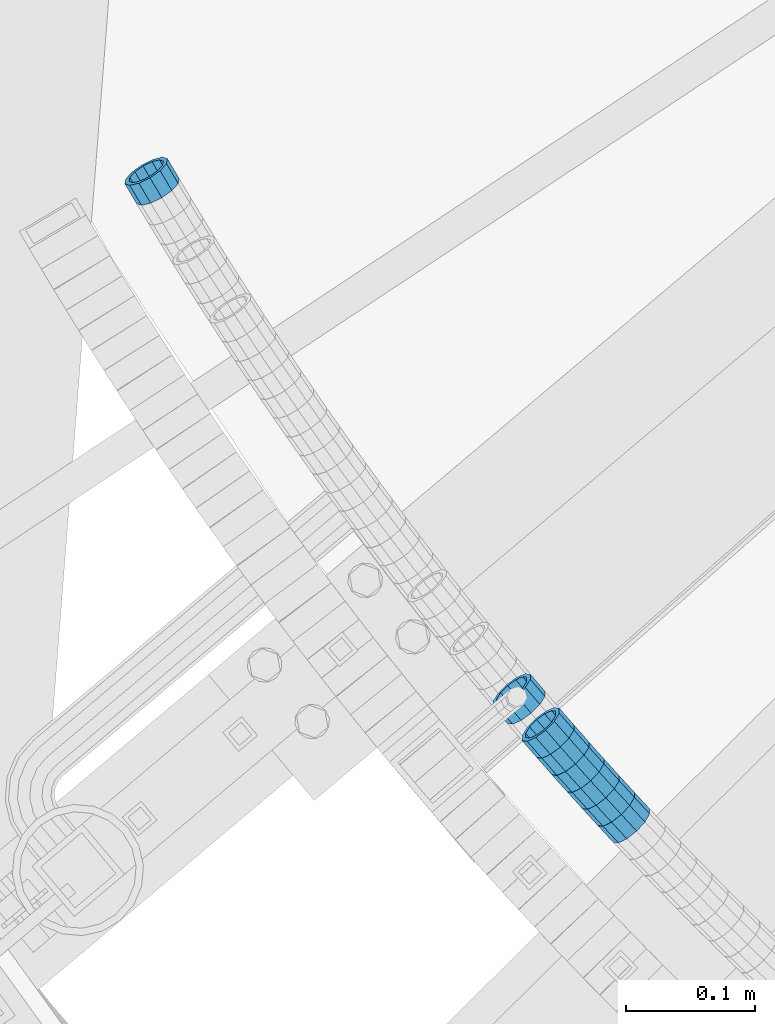
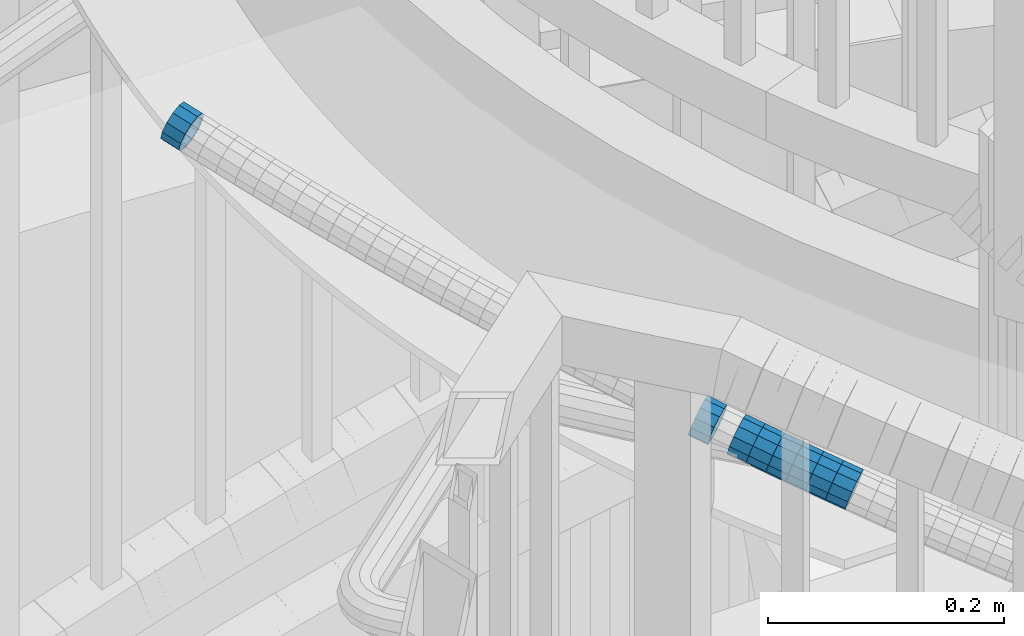
# One storey, part 654 of 975: 8 beams.
"""IFC2X3 building model written with IfcOpenShell, lengths in millimetres."""

from ifc_helpers import new_model, si_unit, frame, origin_with_axes, place, context, subcontext, project, spatial, faceted_brep, material, type_object, element, save


model = new_model("IFC2X3")

# Units and contexts
model_context = context("Model", 3, precision=1e-05, world=origin_with_axes())
body_context = subcontext(model_context, "Body", "Model", "MODEL_VIEW")
ifc_project = project(units=[si_unit("LENGTHUNIT", "METRE", prefix="MILLI"), si_unit("AREAUNIT", "SQUARE_METRE"), si_unit("VOLUMEUNIT", "CUBIC_METRE"), si_unit("MASSUNIT", "GRAM", prefix="KILO"), si_unit("TIMEUNIT", "SECOND"), si_unit("PLANEANGLEUNIT", "RADIAN"), si_unit("SOLIDANGLEUNIT", "STERADIAN"), si_unit("THERMODYNAMICTEMPERATUREUNIT", "DEGREE_CELSIUS"), si_unit("LUMINOUSINTENSITYUNIT", "LUMEN")], contexts=[model_context])

# Site, building, storey
site_placement = place(None, origin_with_axes())
site = spatial("IfcSite", under=ifc_project, at=site_placement, CompositionType="ELEMENT")
building_placement = place(site_placement, origin_with_axes())
building = spatial("IfcBuilding", under=site, at=building_placement, Name="Undefined", CompositionType="ELEMENT")
storey_placement = place(building_placement, origin_with_axes())
storey = spatial("IfcBuildingStorey", under=building, at=storey_placement, Name="Undefined", CompositionType="ELEMENT", Elevation=0.0)

# Beams
ifc_material = material()
beam_type = type_object("IfcBeamType", PredefinedType="NOTDEFINED")
beam_1_placement = place(storey_placement, frame((32604.8351762389, 1604.81809732686, 5002.69902407307), z_axis=(0.759662691195535, 0.650317303787588, -9.46447471505961e-11), x_axis=(0.617920099668258, -0.721818169612514, -0.311694209832667)))
element("IfcBeam", 1, at=beam_1_placement, inside=storey, type_object=beam_type, material=ifc_material, Name="WALL", context=body_context, shape_type="Brep", body=[
    faceted_brep([(-2.1246523829177e-07, -15.367000000002, 0.0), (-1.83998054126278e-07, -13.3082123799541, 7.68350000000009), (18.2939880835056, -13.3082123799395, 7.68349999996644), (18.2939880835038, -15.3669999999856, -2.5465851649642e-11), (-1.06232619145885e-07, -7.68349999999919, 13.3082123799559), (18.2939880835092, -7.68349999998463, 13.3082123799286), (-3.63797880709171e-12, 3.63797880709171e-12, 15.3670000000002), (18.2939880835129, 1.2732925824821e-11, 15.3669999999729), (1.06225343188271e-07, 7.68350000000646, 13.3082123799559), (18.2939880835183, 7.6835000000101, 13.3082123799395), (1.8399441614747e-07, 13.308212379965, 7.68350000000009), (18.2939880835256, 13.308212379965, 7.68349999998827), (2.12461600312963e-07, 15.3670000000093, 0.0), (18.2939880835256, 15.3670000000093, -3.63797880709171e-12), (1.8399441614747e-07, 13.308212379965, -7.68350000000009), (18.2939880835256, 13.308212379965, -7.68350000000282), (1.06225343188271e-07, 7.68350000000646, -13.3082123799559), (18.2939880835256, 7.6835000000101, -13.3082123799613), (-3.63797880709171e-12, 3.63797880709171e-12, -15.3670000000002), (18.293988083522, 1.09139364212751e-11, -15.3670000000129), (-1.06232619145885e-07, -7.68349999999919, -13.3082123799559), (18.2939880835129, -7.68349999998827, -13.3082123799722), (-1.83998054126278e-07, -13.3082123799541, -7.68350000000009), (18.2939880835092, -13.3082123799413, -7.68350000002465), (-2.63386027654633e-07, -19.0500000000029, 0.0), (-2.28097633225843e-07, -16.4977839420972, -9.52499999999964), (18.2939880835056, -16.497783942079, -9.52500000002328), (18.2939880835038, -19.0499999999847, -3.63797880709171e-11), (-1.31691194837913e-07, -9.52500000000146, -16.4977839420935), (18.2939880835165, -9.5249999999869, -16.4977839421081), (-3.63797880709171e-12, 3.63797880709171e-12, -19.0500000000002), (18.293988083522, 1.09139364212751e-11, -19.0500000000065), (1.31687556859106e-07, 9.52500000000509, -16.4977839420935), (18.2939880835256, 9.52500000000873, -16.4977839420935), (2.28097633225843e-07, 16.4977839421044, -9.52499999999964), (18.2939880835329, 16.4977839421008, -9.52499999999418), (2.63382389675826e-07, 19.0500000000138, 0.0), (18.2939880835311, 19.0500000000065, 0.0), (2.28097633225843e-07, 16.4977839421044, 9.52499999999964), (18.2939880835256, 16.4977839421044, 9.52499999999054), (1.31687556859106e-07, 9.52500000000509, 16.4977839420935), (18.2939880835183, 9.52500000001055, 16.4977839420753), (-3.63797880709171e-12, 3.63797880709171e-12, 19.0500000000002), (18.2939880835129, 1.2732925824821e-11, 19.0499999999738), (-1.31691194837913e-07, -9.52500000000146, 16.4977839420935), (18.2939880835056, -9.52499999998508, 16.4977839420608), (-2.28097633225843e-07, -16.4977839420972, 9.52499999999964), (18.2939880835056, -16.497783942079, 9.52499999996871)], [[[0, 1, 2, 3]], [[1, 4, 5, 2]], [[4, 6, 7, 5]], [[6, 8, 9, 7]], [[8, 10, 11, 9]], [[10, 12, 13, 11]], [[12, 14, 15, 13]], [[14, 16, 17, 15]], [[16, 18, 19, 17]], [[18, 20, 21, 19]], [[20, 22, 23, 21]], [[22, 0, 3, 23]], [[24, 25, 26, 27]], [[25, 28, 29, 26]], [[28, 30, 31, 29]], [[30, 32, 33, 31]], [[32, 34, 35, 33]], [[34, 36, 37, 35]], [[36, 38, 39, 37]], [[38, 40, 41, 39]], [[40, 42, 43, 41]], [[42, 44, 45, 43]], [[44, 46, 47, 45]], [[46, 24, 27, 47]], [[29, 31, 33, 35, 37, 39, 41, 43, 45, 47, 27, 26], [5, 7, 9, 11, 13, 15, 17, 19, 21, 23, 3, 2]], [[46, 44, 42, 40, 38, 36, 34, 32, 30, 28, 25, 24], [22, 20, 18, 16, 14, 12, 10, 8, 6, 4, 1, 0]]]),
])
beam_2_placement = place(storey_placement, frame((32638.6552178564, 1565.49242826471, 4985.70988281313), z_axis=(0.751164898388857, 0.660114607798114, -1.34774381876923e-10), x_axis=(0.626853052642323, -0.713315542592967, -0.313426525821128)))
element("IfcBeam", 2, at=beam_2_placement, inside=storey, type_object=beam_type, material=ifc_material, Name="WALL", context=body_context, shape_type="Brep", body=[
    faceted_brep([(-2.1246523829177e-07, -15.367000000002, 0.0), (-1.83998054126278e-07, -13.3082123799541, 7.68350000000009), (18.5143187830763, -13.3082123799722, 7.68350000001374), (18.5143187830618, -15.3670000000093, 3.63797880709171e-12), (-1.06232619145885e-07, -7.68349999999919, 13.3082123799559), (18.5143187830836, -7.68350000002101, 13.3082123799722), (-3.63797880709171e-12, 3.63797880709171e-12, 15.3670000000002), (18.5143187830763, -1.81898940354586e-11, 15.3670000000166), (1.06225343188271e-07, 7.68350000000646, 13.3082123799559), (18.5143187830581, 7.68349999999009, 13.3082123799613), (1.8399441614747e-07, 13.308212379965, 7.68350000000009), (18.5143187830363, 13.3082123799559, 7.68349999999191), (2.12461600312963e-07, 15.3670000000093, 0.0), (18.5143187830108, 15.3670000000111, -2.18278728425503e-11), (1.8399441614747e-07, 13.308212379965, -7.68350000000009), (18.514318782989, 13.3082123799722, -7.68350000003193), (1.06225343188271e-07, 7.68350000000646, -13.3082123799559), (18.5143187829854, 7.68350000002101, -13.3082123799904), (-3.63797880709171e-12, 3.63797880709171e-12, -15.3670000000002), (18.5143187829926, 1.81898940354586e-11, -15.3670000000311), (-1.06232619145885e-07, -7.68349999999919, -13.3082123799559), (18.5143187830108, -7.68349999999191, -13.3082123799795), (-1.83998054126278e-07, -13.3082123799541, -7.68350000000009), (18.5143187830363, -13.3082123799559, -7.6835000000101), (-2.63386027654633e-07, -19.0500000000029, 0.0), (-2.28097633225843e-07, -16.4977839420972, -9.52499999999964), (18.5143187830363, -16.4977839420935, -9.52500000000873), (18.5143187830654, -19.0500000000102, 7.27595761418343e-12), (-1.31691194837913e-07, -9.52500000000146, -16.4977839420935), (18.5143187830035, -9.5249999999869, -16.497783942119), (-3.63797880709171e-12, 3.63797880709171e-12, -19.0500000000002), (18.5143187829854, 2.00088834390044e-11, -19.0500000000357), (1.31687556859106e-07, 9.52500000000509, -16.4977839420935), (18.5143187829744, 9.5250000000251, -16.4977839421408), (2.28097633225843e-07, 16.4977839421044, -9.52499999999964), (18.5143187829854, 16.4977839421135, -9.52500000003783), (2.63382389675826e-07, 19.0500000000138, 0.0), (18.5143187830035, 19.050000000012, -2.5465851649642e-11), (2.28097633225843e-07, 16.4977839421044, 9.52499999999964), (18.5143187830326, 16.4977839420935, 9.52499999999054), (1.31687556859106e-07, 9.52500000000509, 16.4977839420935), (18.5143187830654, 9.52499999998872, 16.4977839421008), (-3.63797880709171e-12, 3.63797880709171e-12, 19.0500000000002), (18.5143187830836, -1.81898940354586e-11, 19.0500000000211), (-1.31691194837913e-07, -9.52500000000146, 16.4977839420935), (18.5143187830981, -9.52500000002328, 16.4977839421226), (-2.28097633225843e-07, -16.4977839420972, 9.52499999999964), (18.5143187830872, -16.4977839421135, 9.52500000001965)], [[[0, 1, 2, 3]], [[1, 4, 5, 2]], [[4, 6, 7, 5]], [[6, 8, 9, 7]], [[8, 10, 11, 9]], [[10, 12, 13, 11]], [[12, 14, 15, 13]], [[14, 16, 17, 15]], [[16, 18, 19, 17]], [[18, 20, 21, 19]], [[20, 22, 23, 21]], [[22, 0, 3, 23]], [[24, 25, 26, 27]], [[25, 28, 29, 26]], [[28, 30, 31, 29]], [[30, 32, 33, 31]], [[32, 34, 35, 33]], [[34, 36, 37, 35]], [[36, 38, 39, 37]], [[38, 40, 41, 39]], [[40, 42, 43, 41]], [[42, 44, 45, 43]], [[44, 46, 47, 45]], [[46, 24, 27, 47]], [[29, 31, 33, 35, 37, 39, 41, 43, 45, 47, 27, 26], [5, 7, 9, 11, 13, 15, 17, 19, 21, 23, 3, 2]], [[46, 44, 42, 40, 38, 36, 34, 32, 30, 28, 25, 24], [22, 20, 18, 16, 14, 12, 10, 8, 6, 4, 1, 0]]]),
])
beam_3_placement = place(storey_placement, frame((32661.9429280183, 1539.16314702104, 4974.18099729021), z_axis=(0.740455314388055, 0.67210559244399, -2.18339664570522e-10), x_axis=(0.639258954897748, -0.704268340887313, -0.308794579950605)))
element("IfcBeam", 3, at=beam_3_placement, inside=storey, type_object=beam_type, material=ifc_material, Name="WALL", context=body_context, shape_type="Brep", body=[
    faceted_brep([(-2.1246523829177e-07, -15.367000000002, 0.0), (-1.83998054126278e-07, -13.3082123799541, 7.68350000000009), (18.4599566630168, -13.3082123799522, 7.68349999999555), (18.4599566630277, -15.3670000000002, 3.63797880709171e-12), (-1.06232619145885e-07, -7.68349999999919, 13.3082123799559), (18.4599566630131, -7.68349999999373, 13.3082123799468), (-3.63797880709171e-12, 3.63797880709171e-12, 15.3670000000002), (18.4599566630059, 7.27595761418343e-12, 15.3669999999911), (1.06225343188271e-07, 7.68350000000646, 13.3082123799559), (18.4599566630059, 7.68350000000646, 13.3082123799431), (1.8399441614747e-07, 13.308212379965, 7.68350000000009), (18.4599566630131, 13.3082123799595, 7.68349999999555), (2.12461600312963e-07, 15.3670000000093, 0.0), (18.4599566630241, 15.3670000000002, 0.0), (1.8399441614747e-07, 13.308212379965, -7.68350000000009), (18.4599566630313, 13.3082123799522, -7.68349999999191), (1.06225343188271e-07, 7.68350000000646, -13.3082123799559), (18.459956663035, 7.68349999999555, -13.3082123799431), (-3.63797880709171e-12, 3.63797880709171e-12, -15.3670000000002), (18.459956663035, -3.63797880709171e-12, -15.3669999999875), (-1.06232619145885e-07, -7.68349999999919, -13.3082123799559), (18.459956663035, -7.68350000000464, -13.3082123799431), (-1.83998054126278e-07, -13.3082123799541, -7.68350000000009), (18.459956663035, -13.3082123799559, -7.68349999999191), (-2.63386027654633e-07, -19.0500000000029, 0.0), (-2.28097633225843e-07, -16.4977839420972, -9.52499999999964), (18.459956663035, -16.4977839420953, -9.5249999999869), (18.4599566630241, -19.0499999999975, 3.63797880709171e-12), (-1.31691194837913e-07, -9.52500000000146, -16.4977839420935), (18.4599566630386, -9.52500000000327, -16.497783942079), (-3.63797880709171e-12, 3.63797880709171e-12, -19.0500000000002), (18.4599566630422, -5.45696821063757e-12, -19.0499999999811), (1.31687556859106e-07, 9.52500000000509, -16.4977839420935), (18.4599566630386, 9.52499999999418, -16.497783942079), (2.28097633225843e-07, 16.4977839421044, -9.52499999999964), (18.4599566630277, 16.4977839420917, -9.52499999999418), (2.63382389675826e-07, 19.0500000000138, 0.0), (18.4599566630168, 19.0500000000011, -3.63797880709171e-12), (2.28097633225843e-07, 16.4977839421044, 9.52499999999964), (18.4599566630131, 16.4977839420972, 9.52499999999054), (1.31687556859106e-07, 9.52500000000509, 16.4977839420935), (18.4599566630095, 9.52500000000691, 16.497783942079), (-3.63797880709171e-12, 3.63797880709171e-12, 19.0500000000002), (18.4599566630059, 7.27595761418343e-12, 19.0499999999884), (-1.31691194837913e-07, -9.52500000000146, 16.4977839420935), (18.4599566630095, -9.52499999999236, 16.4977839420826), (-2.28097633225843e-07, -16.4977839420972, 9.52499999999964), (18.4599566630168, -16.4977839420881, 9.52499999999418)], [[[0, 1, 2, 3]], [[1, 4, 5, 2]], [[4, 6, 7, 5]], [[6, 8, 9, 7]], [[8, 10, 11, 9]], [[10, 12, 13, 11]], [[12, 14, 15, 13]], [[14, 16, 17, 15]], [[16, 18, 19, 17]], [[18, 20, 21, 19]], [[20, 22, 23, 21]], [[22, 0, 3, 23]], [[24, 25, 26, 27]], [[25, 28, 29, 26]], [[28, 30, 31, 29]], [[30, 32, 33, 31]], [[32, 34, 35, 33]], [[34, 36, 37, 35]], [[36, 38, 39, 37]], [[38, 40, 41, 39]], [[40, 42, 43, 41]], [[42, 44, 45, 43]], [[44, 46, 47, 45]], [[46, 24, 27, 47]], [[29, 31, 33, 35, 37, 39, 41, 43, 45, 47, 27, 26], [5, 7, 9, 11, 13, 15, 17, 19, 21, 23, 3, 2]], [[46, 44, 42, 40, 38, 36, 34, 32, 30, 28, 25, 24], [22, 20, 18, 16, 14, 12, 10, 8, 6, 4, 1, 0]]]),
])
beam_4_placement = place(storey_placement, frame((32627.2642007795, 1578.49172213886, 4991.40775295445), z_axis=(0.751859704925963, 0.659323125719585, -5.3410985856317e-11), x_axis=(0.626175166039993, -0.714059400045601, -0.313087583019996)))
element("IfcBeam", 4, at=beam_4_placement, inside=storey, type_object=beam_type, material=ifc_material, Name="WALL", context=body_context, shape_type="Brep", body=[
    faceted_brep([(-2.1246523829177e-07, -15.367000000002, 0.0), (-1.83998054126278e-07, -13.3082123799541, 7.68350000000009), (18.2060429528137, -13.3082123799522, 7.68349999999555), (18.2060429528246, -15.3669999999966, 3.63797880709171e-12), (-1.06232619145885e-07, -7.68349999999919, 13.3082123799559), (18.2060429527992, -7.68349999999373, 13.3082123799359), (-3.63797880709171e-12, 3.63797880709171e-12, 15.3670000000002), (18.2060429527883, 5.45696821063757e-12, 15.3669999999656), (1.06225343188271e-07, 7.68350000000646, 13.3082123799559), (18.206042952781, 7.68350000000464, 13.308212379914), (1.8399441614747e-07, 13.308212379965, 7.68350000000009), (18.206042952781, 13.3082123799595, 7.68349999996281), (2.12461600312963e-07, 15.3670000000093, 0.0), (18.2060429527883, 15.3670000000038, -3.27418092638254e-11), (1.8399441614747e-07, 13.308212379965, -7.68350000000009), (18.2060429527992, 13.3082123799559, -7.68350000002101), (1.06225343188271e-07, 7.68350000000646, -13.3082123799559), (18.2060429528137, 7.683500000001, -13.3082123799613), (-3.63797880709171e-12, 3.63797880709171e-12, -15.3670000000002), (18.2060429528246, -1.81898940354586e-12, -15.3669999999947), (-1.06232619145885e-07, -7.68349999999919, -13.3082123799559), (18.2060429528319, -7.683500000001, -13.3082123799395), (-1.83998054126278e-07, -13.3082123799541, -7.68350000000009), (18.2060429528283, -13.3082123799559, -7.68349999998827), (-2.63386027654633e-07, -19.0500000000029, 0.0), (-2.28097633225843e-07, -16.4977839420972, -9.52499999999964), (18.2060429528356, -16.4977839420953, -9.52499999997599), (18.2060429528283, -19.0499999999975, 1.09139364212751e-11), (-1.31691194837913e-07, -9.52500000000146, -16.4977839420935), (18.2060429528356, -9.52500000000146, -16.4977839420717), (-3.63797880709171e-12, 3.63797880709171e-12, -19.0500000000002), (18.2060429528283, -1.81898940354586e-12, -19.0499999999884), (1.31687556859106e-07, 9.52500000000509, -16.4977839420935), (18.2060429528137, 9.52499999999964, -16.4977839421008), (2.28097633225843e-07, 16.4977839421044, -9.52499999999964), (18.2060429527955, 16.4977839420953, -9.52500000002328), (2.63382389675826e-07, 19.0500000000138, 0.0), (18.2060429527846, 19.0500000000029, -4.00177668780088e-11), (2.28097633225843e-07, 16.4977839421044, 9.52499999999964), (18.206042952781, 16.497783942099, 9.52499999995052), (1.31687556859106e-07, 9.52500000000509, 16.4977839420935), (18.2060429527774, 9.52500000000509, 16.4977839420426), (-3.63797880709171e-12, 3.63797880709171e-12, 19.0500000000002), (18.2060429527846, 5.45696821063757e-12, 19.0499999999629), (-1.31691194837913e-07, -9.52500000000146, 16.4977839420935), (18.2060429527992, -9.52499999999418, 16.4977839420681), (-2.28097633225843e-07, -16.4977839420972, 9.52499999999964), (18.2060429528174, -16.4977839420899, 9.52499999999782)], [[[0, 1, 2, 3]], [[1, 4, 5, 2]], [[4, 6, 7, 5]], [[6, 8, 9, 7]], [[8, 10, 11, 9]], [[10, 12, 13, 11]], [[12, 14, 15, 13]], [[14, 16, 17, 15]], [[16, 18, 19, 17]], [[18, 20, 21, 19]], [[20, 22, 23, 21]], [[22, 0, 3, 23]], [[24, 25, 26, 27]], [[25, 28, 29, 26]], [[28, 30, 31, 29]], [[30, 32, 33, 31]], [[32, 34, 35, 33]], [[34, 36, 37, 35]], [[36, 38, 39, 37]], [[38, 40, 41, 39]], [[40, 42, 43, 41]], [[42, 44, 45, 43]], [[44, 46, 47, 45]], [[46, 24, 27, 47]], [[29, 31, 33, 35, 37, 39, 41, 43, 45, 47, 27, 26], [5, 7, 9, 11, 13, 15, 17, 19, 21, 23, 3, 2]], [[46, 44, 42, 40, 38, 36, 34, 32, 30, 28, 25, 24], [22, 20, 18, 16, 14, 12, 10, 8, 6, 4, 1, 0]]]),
])
beam_5_placement = place(storey_placement, frame((32650.2477631625, 1552.19500331894, 4979.88763025497), z_axis=(0.743294146218536, 0.668964731654262, -1.31398337543942e-10), x_axis=(0.636038666897884, -0.706709629886569, -0.309864991950287)))
element("IfcBeam", 5, at=beam_5_placement, inside=storey, type_object=beam_type, material=ifc_material, Name="WALL", context=body_context, shape_type="Brep", body=[
    faceted_brep([(-2.1246523829177e-07, -15.367000000002, 0.0), (-1.83998054126278e-07, -13.3082123799541, 7.68350000000009), (18.4002717371586, -13.3082123799486, 7.6835000000101), (18.4002717371732, -15.3670000000002, 2.5465851649642e-11), (-1.06232619145885e-07, -7.68349999999919, 13.3082123799559), (18.4002717371368, -7.68349999998645, 13.3082123799431), (-3.63797880709171e-12, 3.63797880709171e-12, 15.3670000000002), (18.400271737115, 2.00088834390044e-11, 15.3669999999656), (1.06225343188271e-07, 7.68350000000646, 13.3082123799559), (18.4002717371004, 7.68350000002283, 13.3082123799068), (1.8399441614747e-07, 13.308212379965, 7.68350000000009), (18.4002717370895, 13.3082123799741, 7.68349999994462), (2.12461600312963e-07, 15.3670000000093, 0.0), (18.4002717370931, 15.3670000000147, -5.45696821063757e-11), (1.8399441614747e-07, 13.308212379965, -7.68350000000009), (18.4002717371004, 13.3082123799632, -7.6835000000392), (1.06225343188271e-07, 7.68350000000646, -13.3082123799559), (18.4002717371259, 7.68349999999919, -13.3082123799759), (-3.63797880709171e-12, 3.63797880709171e-12, -15.3670000000002), (18.4002717371513, -5.45696821063757e-12, -15.3669999999984), (-1.06232619145885e-07, -7.68349999999919, -13.3082123799559), (18.4002717371659, -7.68350000000646, -13.3082123799395), (-1.83998054126278e-07, -13.3082123799541, -7.68350000000009), (18.4002717371732, -13.3082123799613, -7.68349999997736), (-2.63386027654633e-07, -19.0500000000029, 0.0), (-2.28097633225843e-07, -16.4977839420972, -9.52499999999964), (18.4002717371877, -16.4977839421026, -9.52499999996508), (18.4002717371841, -19.0500000000029, 3.63797880709171e-11), (-1.31691194837913e-07, -9.52500000000146, -16.4977839420935), (18.4002717371768, -9.52500000001055, -16.4977839420681), (-3.63797880709171e-12, 3.63797880709171e-12, -19.0500000000002), (18.400271737155, -9.09494701772928e-12, -19.0499999999956), (1.31687556859106e-07, 9.52500000000509, -16.4977839420935), (18.4002717371295, 9.52499999999782, -16.4977839421153), (2.28097633225843e-07, 16.4977839421044, -9.52499999999964), (18.4002717370968, 16.4977839421026, -9.52500000005239), (2.63382389675826e-07, 19.0500000000138, 0.0), (18.4002717370822, 19.0500000000156, -6.54836185276508e-11), (2.28097633225843e-07, 16.4977839421044, 9.52499999999964), (18.4002717370786, 16.4977839421172, 9.52499999993233), (1.31687556859106e-07, 9.52500000000509, 16.4977839420935), (18.4002717370859, 9.5250000000251, 16.497783942039), (-3.63797880709171e-12, 3.63797880709171e-12, 19.0500000000002), (18.4002717371113, 2.36468622460961e-11, 19.0499999999629), (-1.31691194837913e-07, -9.52500000000146, 16.4977839420935), (18.4002717371368, -9.52499999998327, 16.4977839420826), (-2.28097633225843e-07, -16.4977839420972, 9.52499999999964), (18.4002717371623, -16.4977839420844, 9.52500000001601)], [[[0, 1, 2, 3]], [[1, 4, 5, 2]], [[4, 6, 7, 5]], [[6, 8, 9, 7]], [[8, 10, 11, 9]], [[10, 12, 13, 11]], [[12, 14, 15, 13]], [[14, 16, 17, 15]], [[16, 18, 19, 17]], [[18, 20, 21, 19]], [[20, 22, 23, 21]], [[22, 0, 3, 23]], [[24, 25, 26, 27]], [[25, 28, 29, 26]], [[28, 30, 31, 29]], [[30, 32, 33, 31]], [[32, 34, 35, 33]], [[34, 36, 37, 35]], [[36, 38, 39, 37]], [[38, 40, 41, 39]], [[40, 42, 43, 41]], [[42, 44, 45, 43]], [[44, 46, 47, 45]], [[46, 24, 27, 47]], [[29, 31, 33, 35, 37, 39, 41, 43, 45, 47, 27, 26], [5, 7, 9, 11, 13, 15, 17, 19, 21, 23, 3, 2]], [[46, 44, 42, 40, 38, 36, 34, 32, 30, 28, 25, 24], [22, 20, 18, 16, 14, 12, 10, 8, 6, 4, 1, 0]]]),
])
beam_6_placement = place(storey_placement, frame((32673.6756956159, 1526.19999119512, 4968.50470277997), z_axis=(0.737625013293652, 0.675210589196837, -1.74704837263562e-11), x_axis=(0.641371986286191, -0.700658472312666, -0.312601472139506)))
element("IfcBeam", 6, at=beam_6_placement, inside=storey, type_object=beam_type, material=ifc_material, Name="WALL", context=body_context, shape_type="Brep", body=[
    faceted_brep([(-2.1246523829177e-07, -15.367000000002, 0.0), (-1.83998054126278e-07, -13.3082123799541, 7.68350000000009), (18.5504716921532, -13.3082123799668, 7.68350000001737), (18.5504716921569, -15.3670000000111, 1.81898940354586e-11), (-1.06232619145885e-07, -7.68349999999919, 13.3082123799559), (18.5504716921569, -7.68350000001192, 13.3082123799722), (-3.63797880709171e-12, 3.63797880709171e-12, 15.3670000000002), (18.5504716921641, -1.2732925824821e-11, 15.3670000000238), (1.06225343188271e-07, 7.68350000000646, 13.3082123799559), (18.5504716921714, 7.68349999998645, 13.3082123799868), (1.8399441614747e-07, 13.308212379965, 7.68350000000009), (18.5504716921787, 13.308212379945, 7.68350000003193), (2.12461600312963e-07, 15.3670000000093, 0.0), (18.5504716921787, 15.3669999999929, 3.27418092638254e-11), (1.8399441614747e-07, 13.308212379965, -7.68350000000009), (18.5504716921787, 13.3082123799522, -7.68349999997008), (1.06225343188271e-07, 7.68350000000646, -13.3082123799559), (18.5504716921787, 7.68349999999555, -13.3082123799213), (-3.63797880709171e-12, 3.63797880709171e-12, -15.3670000000002), (18.5504716921714, -3.63797880709171e-12, -15.3669999999765), (-1.06232619145885e-07, -7.68349999999919, -13.3082123799559), (18.5504716921641, -7.68350000000464, -13.3082123799359), (-1.83998054126278e-07, -13.3082123799541, -7.68350000000009), (18.5504716921605, -13.3082123799632, -7.683499999981), (-2.63386027654633e-07, -19.0500000000029, 0.0), (-2.28097633225843e-07, -16.4977839420972, -9.52499999999964), (18.5504716921569, -16.4977839421026, -9.52499999997963), (18.5504716921532, -19.0500000000102, 1.09139364212751e-11), (-1.31691194837913e-07, -9.52500000000146, -16.4977839420935), (18.5504716921605, -9.52500000000509, -16.4977839420681), (-3.63797880709171e-12, 3.63797880709171e-12, -19.0500000000002), (18.5504716921678, -1.81898940354586e-12, -19.0499999999774), (1.31687556859106e-07, 9.52500000000509, -16.4977839420935), (18.5504716921823, 9.52499999999782, -16.4977839420608), (2.28097633225843e-07, 16.4977839421044, -9.52499999999964), (18.550471692186, 16.4977839420881, -9.52499999996508), (2.63382389675826e-07, 19.0500000000138, 0.0), (18.550471692186, 19.049999999992, 3.63797880709171e-11), (2.28097633225843e-07, 16.4977839421044, 9.52499999999964), (18.5504716921787, 16.4977839420844, 9.52500000003056), (1.31687556859106e-07, 9.52500000000509, 16.4977839420935), (18.5504716921678, 9.52499999998872, 16.497783942119), (-3.63797880709171e-12, 3.63797880709171e-12, 19.0500000000002), (18.5504716921605, -1.2732925824821e-11, 19.0500000000211), (-1.31691194837913e-07, -9.52500000000146, 16.4977839420935), (18.5504716921569, -9.52500000001419, 16.4977839421117), (-2.28097633225843e-07, -16.4977839420972, 9.52499999999964), (18.5504716921532, -16.4977839421063, 9.52500000001601)], [[[0, 1, 2, 3]], [[1, 4, 5, 2]], [[4, 6, 7, 5]], [[6, 8, 9, 7]], [[8, 10, 11, 9]], [[10, 12, 13, 11]], [[12, 14, 15, 13]], [[14, 16, 17, 15]], [[16, 18, 19, 17]], [[18, 20, 21, 19]], [[20, 22, 23, 21]], [[22, 0, 3, 23]], [[24, 25, 26, 27]], [[25, 28, 29, 26]], [[28, 30, 31, 29]], [[30, 32, 33, 31]], [[32, 34, 35, 33]], [[34, 36, 37, 35]], [[36, 38, 39, 37]], [[38, 40, 41, 39]], [[40, 42, 43, 41]], [[42, 44, 45, 43]], [[44, 46, 47, 45]], [[46, 24, 27, 47]], [[29, 31, 33, 35, 37, 39, 41, 43, 45, 47, 27, 26], [5, 7, 9, 11, 13, 15, 17, 19, 21, 23, 3, 2]], [[46, 44, 42, 40, 38, 36, 34, 32, 30, 28, 25, 24], [22, 20, 18, 16, 14, 12, 10, 8, 6, 4, 1, 0]]]),
])
beam_7_placement = place(storey_placement, frame((32685.5747540195, 1513.13342554666, 4962.68888269739), z_axis=(0.732385782470827, 0.680889907132273, -7.29605744709263e-11), x_axis=(0.647332126991127, -0.696290018990435, -0.310066648995734)))
element("IfcBeam", 7, at=beam_7_placement, inside=storey, type_object=beam_type, material=ifc_material, Name="WALL", context=body_context, shape_type="Brep", body=[
    faceted_brep([(-2.1246523829177e-07, -15.367000000002, 0.0), (-1.83998054126278e-07, -13.3082123799541, 7.68350000000009), (18.3831444535936, -13.3082123799741, 7.68350000002465), (18.3831444535717, -15.3670000000056, 7.27595761418343e-12), (-1.06232619145885e-07, -7.68349999999919, 13.3082123799559), (18.3831444536154, -7.68350000002283, 13.3082123799941), (-3.63797880709171e-12, 3.63797880709171e-12, 15.3670000000002), (18.3831444536409, -3.09228198602796e-11, 15.3670000000493), (1.06225343188271e-07, 7.68350000000646, 13.3082123799559), (18.3831444536554, 7.68349999996462, 13.3082123800159), (1.8399441614747e-07, 13.308212379965, 7.68350000000009), (18.3831444536554, 13.3082123799231, 7.68350000006103), (2.12461600312963e-07, 15.3670000000093, 0.0), (18.3831444536409, 15.3669999999747, 5.0931703299284e-11), (1.8399441614747e-07, 13.308212379965, -7.68350000000009), (18.3831444536154, 13.3082123799413, -7.68349999996281), (1.06225343188271e-07, 7.68350000000646, -13.3082123799559), (18.3831444535899, 7.68349999999737, -13.3082123799359), (-3.63797880709171e-12, 3.63797880709171e-12, -15.3670000000002), (18.3831444535681, 5.45696821063757e-12, -15.3669999999947), (-1.06232619145885e-07, -7.68349999999919, -13.3082123799559), (18.3831444535608, -7.68349999999737, -13.3082123799577), (-1.83998054126278e-07, -13.3082123799541, -7.68350000000009), (18.3831444535535, -13.3082123799522, -7.68350000000282), (-2.63386027654633e-07, -19.0500000000029, 0.0), (-2.28097633225843e-07, -16.4977839420972, -9.52499999999964), (18.3831444535426, -16.4977839420862, -9.52500000000873), (18.3831444535608, -19.0500000000047, 3.63797880709171e-12), (-1.31691194837913e-07, -9.52500000000146, -16.4977839420935), (18.383144453539, -9.52499999998872, -16.4977839421081), (-3.63797880709171e-12, 3.63797880709171e-12, -19.0500000000002), (18.3831444535572, 9.09494701772928e-12, -19.0500000000029), (1.31687556859106e-07, 9.52500000000509, -16.4977839420935), (18.3831444535863, 9.52499999999964, -16.497783942079), (2.28097633225843e-07, 16.4977839421044, -9.52499999999964), (18.383144453619, 16.4977839420808, -9.52499999996508), (2.63382389675826e-07, 19.0500000000138, 0.0), (18.3831444536481, 19.049999999972, 5.45696821063757e-11), (2.28097633225843e-07, 16.4977839421044, 9.52499999999964), (18.3831444536663, 16.4977839420571, 9.52500000006694), (1.31687556859106e-07, 9.52500000000509, 16.4977839420935), (18.3831444536663, 9.52499999996144, 16.4977839421626), (-3.63797880709171e-12, 3.63797880709171e-12, 19.0500000000002), (18.3831444536518, -3.45607986673713e-11, 19.0500000000575), (-1.31691194837913e-07, -9.52500000000146, 16.4977839420935), (18.3831444536263, -9.52500000002874, 16.4977839421372), (-2.28097633225843e-07, -16.4977839420972, 9.52499999999964), (18.3831444535863, -16.4977839421099, 9.52500000001965)], [[[0, 1, 2, 3]], [[1, 4, 5, 2]], [[4, 6, 7, 5]], [[6, 8, 9, 7]], [[8, 10, 11, 9]], [[10, 12, 13, 11]], [[12, 14, 15, 13]], [[14, 16, 17, 15]], [[16, 18, 19, 17]], [[18, 20, 21, 19]], [[20, 22, 23, 21]], [[22, 0, 3, 23]], [[24, 25, 26, 27]], [[25, 28, 29, 26]], [[28, 30, 31, 29]], [[30, 32, 33, 31]], [[32, 34, 35, 33]], [[34, 36, 37, 35]], [[36, 38, 39, 37]], [[38, 40, 41, 39]], [[40, 42, 43, 41]], [[42, 44, 45, 43]], [[44, 46, 47, 45]], [[46, 24, 27, 47]], [[29, 31, 33, 35, 37, 39, 41, 43, 45, 47, 27, 26], [5, 7, 9, 11, 13, 15, 17, 19, 21, 23, 3, 2]], [[46, 44, 42, 40, 38, 36, 34, 32, 30, 28, 25, 24], [22, 20, 18, 16, 14, 12, 10, 8, 6, 4, 1, 0]]]),
])
beam_8_placement = place(storey_placement, frame((32322.4074655405, 2005.96595013159, 5163.47878387479), z_axis=(0.860926528195376, 0.508729312158693, 1.20726326713338e-11), x_axis=(0.483926186171339, -0.818952007289947, -0.308436470109208)))
element("IfcBeam", 8, at=beam_8_placement, inside=storey, type_object=beam_type, material=ifc_material, Name="WALL", context=body_context, shape_type="Brep", body=[
    faceted_brep([(-2.1246523829177e-07, -15.367000000002, 0.0), (-1.83998054126278e-07, -13.3082123799541, 7.68350000000009), (18.804520733067, -13.3082123799541, 7.68350000001737), (18.804520733067, -15.367000000002, 1.81898940354586e-11), (-1.06232619145885e-07, -7.68349999999919, 13.3082123799559), (18.8045207330597, -7.68349999999919, 13.3082123799613), (-3.63797880709171e-12, 3.63797880709171e-12, 15.3670000000002), (18.8045207330579, 0.0, 15.367000000002), (1.06225343188271e-07, 7.68350000000646, 13.3082123799559), (18.8045207330488, 7.68349999999919, 13.3082123799431), (1.8399441614747e-07, 13.308212379965, 7.68350000000009), (18.8045207330451, 13.3082123799522, 7.68349999997736), (2.12461600312963e-07, 15.3670000000093, 0.0), (18.8045207330415, 15.3669999999947, -2.5465851649642e-11), (1.8399441614747e-07, 13.308212379965, -7.68350000000009), (18.8045207330397, 13.3082123799486, -7.68350000002829), (1.06225343188271e-07, 7.68350000000646, -13.3082123799559), (18.8045207330451, 7.68349999999191, -13.3082123799759), (-3.63797880709171e-12, 3.63797880709171e-12, -15.3670000000002), (18.8045207330488, -5.45696821063757e-12, -15.3670000000093), (-1.06232619145885e-07, -7.68349999999919, -13.3082123799559), (18.8045207330561, -7.68350000000464, -13.3082123799577), (-1.83998054126278e-07, -13.3082123799541, -7.68350000000009), (18.8045207330633, -13.3082123799577, -7.68349999998827), (-2.63386027654633e-07, -19.0500000000029, 0.0), (-2.28097633225843e-07, -16.4977839420972, -9.52499999999964), (18.8045207330651, -16.4977839420972, -9.5249999999869), (18.804520733067, -19.0499999999993, 1.81898940354586e-11), (-1.31691194837913e-07, -9.52500000000146, -16.4977839420935), (18.8045207330561, -9.52500000000509, -16.4977839420899), (-3.63797880709171e-12, 3.63797880709171e-12, -19.0500000000002), (18.8045207330506, -7.27595761418343e-12, -19.0500000000102), (1.31687556859106e-07, 9.52500000000509, -16.4977839420935), (18.8045207330433, 9.52499999999054, -16.4977839421153), (2.28097633225843e-07, 16.4977839421044, -9.52499999999964), (18.8045207330379, 16.4977839420862, -9.52500000003056), (2.63382389675826e-07, 19.0500000000138, 0.0), (18.804520733036, 19.0499999999956, -3.27418092638254e-11), (2.28097633225843e-07, 16.4977839421044, 9.52499999999964), (18.8045207330433, 16.4977839420899, 9.52499999997599), (1.31687556859106e-07, 9.52500000000509, 16.4977839420935), (18.8045207330488, 9.52499999999782, 16.497783942079), (-3.63797880709171e-12, 3.63797880709171e-12, 19.0500000000002), (18.8045207330579, 0.0, 19.0499999999993), (-1.31691194837913e-07, -9.52500000000146, 16.4977839420935), (18.8045207330651, -9.52499999999782, 16.4977839421044), (-2.28097633225843e-07, -16.4977839420972, 9.52499999999964), (18.8045207330688, -16.4977839420935, 9.52500000001965)], [[[0, 1, 2, 3]], [[1, 4, 5, 2]], [[4, 6, 7, 5]], [[6, 8, 9, 7]], [[8, 10, 11, 9]], [[10, 12, 13, 11]], [[12, 14, 15, 13]], [[14, 16, 17, 15]], [[16, 18, 19, 17]], [[18, 20, 21, 19]], [[20, 22, 23, 21]], [[22, 0, 3, 23]], [[24, 25, 26, 27]], [[25, 28, 29, 26]], [[28, 30, 31, 29]], [[30, 32, 33, 31]], [[32, 34, 35, 33]], [[34, 36, 37, 35]], [[36, 38, 39, 37]], [[38, 40, 41, 39]], [[40, 42, 43, 41]], [[42, 44, 45, 43]], [[44, 46, 47, 45]], [[46, 24, 27, 47]], [[29, 31, 33, 35, 37, 39, 41, 43, 45, 47, 27, 26], [5, 7, 9, 11, 13, 15, 17, 19, 21, 23, 3, 2]], [[46, 44, 42, 40, 38, 36, 34, 32, 30, 28, 25, 24], [22, 20, 18, 16, 14, 12, 10, 8, 6, 4, 1, 0]]]),
])

save(model, "model.ifc")
